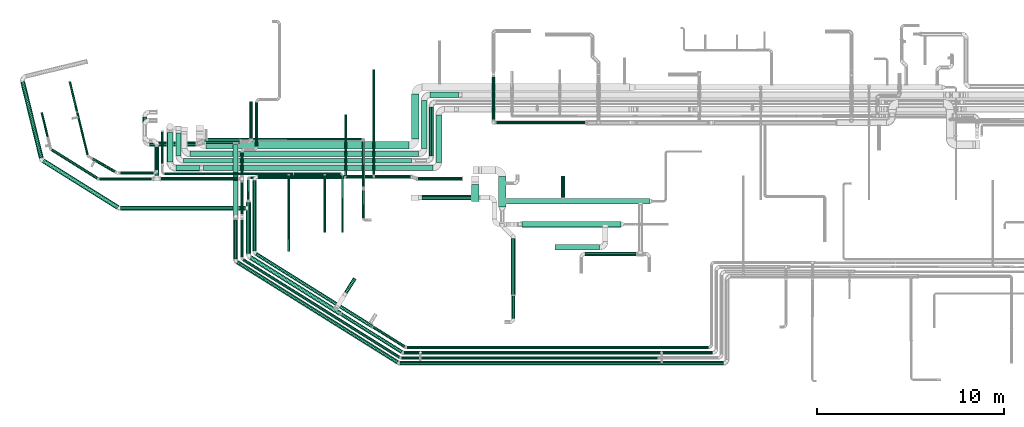
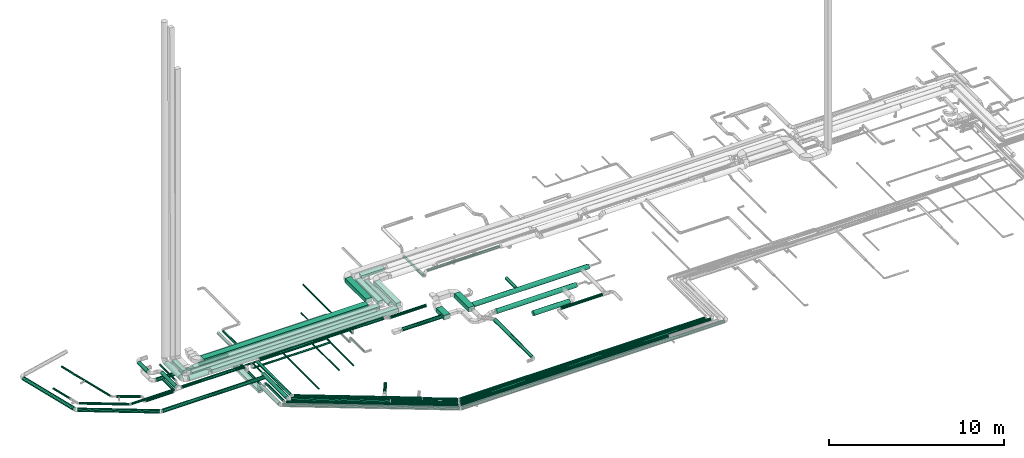
# One storey, part 30 of 92: 75 flow segments.
"""IFC2X3 building model written with IfcOpenShell, lengths in millimetres."""

import ifcopenshell
import ifcopenshell.guid

model = None  # the IFC model being written
_history = None  # IfcOwnerHistory: only IFC2X3 demands one
_inside = {}  # id of a spatial element -> (the spatial element, [elements in it])
_under = {}  # id of a project, library or spatial element -> (it, [spatial elements below it])
_declared = {}  # id of a project -> (the project, [libraries it declares])
_typed = {}  # id of a type object -> (the type object, [elements of that type])
_made_of = {}  # id of a material, layer set ... -> (it, [elements and type objects made of it])


def new_model(schema):
    """Start an empty IFC model of exactly this schema.

    Asked for "IFC4X3", IfcOpenShell would pick the latest addendum, in which some entities
    have other attributes; the version numbers below select the first issue.
    IFC2X3 requires an IfcOwnerHistory on every rooted entity: one is made here for all.
    """
    global model, _history
    if schema == "IFC4X3":
        model = ifcopenshell.file(schema_version=(4, 3, 0, 0))
    else:
        model = ifcopenshell.file(schema=schema)
    _inside.clear()
    _under.clear()
    _declared.clear()
    _typed.clear()
    _made_of.clear()
    _history = None
    if model.schema == "IFC2X3":
        org = make("IfcOrganization", Name="unknown")
        user = make(
            "IfcPersonAndOrganization",
            ThePerson=make("IfcPerson", FamilyName="unknown"),
            TheOrganization=org,
        )
        app = make(
            "IfcApplication",
            ApplicationDeveloper=org,
            Version="unknown",
            ApplicationFullName="unknown",
            ApplicationIdentifier="unknown",
        )
        _history = make(
            "IfcOwnerHistory",
            OwningUser=user,
            OwningApplication=app,
            ChangeAction="ADDED",
            CreationDate=0,
        )
    return model


def make(cls, **values):
    """One entity of the class cls with the attributes given. An attribute that is None is left unset."""
    return model.create_entity(
        cls, **{name: value for name, value in values.items() if value is not None}
    )


def entity(cls, *values):
    """Any entity or typed value of the class cls, its attributes in the order of the schema. None: left unset."""
    e = model.create_entity(cls)
    for i, value in enumerate(values):
        if value is not None:
            e[i] = value
    return e


def rooted(cls, **values):
    """An entity with a GlobalId (a new one), such as an element, a storey or a relation."""
    return make(cls, GlobalId=ifcopenshell.guid.new(), OwnerHistory=_history, **values)


def si_unit(unit_type, name, prefix=None):
    """IfcSIUnit, for example si_unit("LENGTHUNIT", "METRE", prefix="MILLI")."""
    return make("IfcSIUnit", UnitType=unit_type, Prefix=prefix, Name=name)


def converted_unit(unit_type, name, factor, base, dimensions=None, offset=None):
    """IfcConversionBasedUnit, such as the inch: factor (a typed value) times the base unit."""
    return make(
        "IfcConversionBasedUnit"
        if offset is None
        else "IfcConversionBasedUnitWithOffset",
        ConversionOffset=offset,
        Dimensions=None
        if dimensions is None
        else entity("IfcDimensionalExponents", *dimensions),
        UnitType=unit_type,
        Name=name,
        ConversionFactor=make(
            "IfcMeasureWithUnit", ValueComponent=factor, UnitComponent=base
        ),
    )


def derived_unit(unit_type, elements):
    """IfcDerivedUnit: a product of units, each with its exponent."""
    return make(
        "IfcDerivedUnit",
        Elements=[
            make("IfcDerivedUnitElement", Unit=unit, Exponent=power)
            for unit, power in elements
        ],
        UnitType=unit_type,
    )


def assignment(units):
    """IfcUnitAssignment: the units of a project."""
    return None if units is None else make("IfcUnitAssignment", Units=units)


def point(xyz):
    """IfcCartesianPoint."""
    return None if xyz is None else make("IfcCartesianPoint", Coordinates=xyz)


def direction(xyz):
    """IfcDirection."""
    return None if xyz is None else make("IfcDirection", DirectionRatios=xyz)


def frame(location, z_axis=None, x_axis=None):
    """IfcAxis2Placement3D, a coordinate frame: its origin and axes. An axis left out is left unset."""
    return make(
        "IfcAxis2Placement3D",
        Location=point(location),
        Axis=direction(z_axis),
        RefDirection=direction(x_axis),
    )


def frame_2d(location, x_axis=None):
    """IfcAxis2Placement2D, a coordinate frame in the plane: its origin and x axis."""
    return make(
        "IfcAxis2Placement2D", Location=point(location), RefDirection=direction(x_axis)
    )


def origin():
    """The frame at (0, 0, 0) with its axes left unset."""
    return frame((0.0, 0.0, 0.0))


def origin_2d_with_axis():
    """The frame at (0, 0) in the plane with the x axis (1, 0) written out."""
    return frame_2d((0.0, 0.0), x_axis=(1.0, 0.0))


def place(relative_to, where):
    """IfcLocalPlacement: puts the frame where relative to a parent placement (None: the world)."""
    return make(
        "IfcLocalPlacement", PlacementRelTo=relative_to, RelativePlacement=where
    )


def context(
    kind, dimensions, precision=None, world=None, true_north=None, identifier=None
):
    """IfcGeometricRepresentationContext, for example the 3D "Model" context."""
    return make(
        "IfcGeometricRepresentationContext",
        ContextIdentifier=identifier,
        ContextType=kind,
        CoordinateSpaceDimension=dimensions,
        Precision=precision,
        WorldCoordinateSystem=world,
        TrueNorth=true_north,
    )


def subcontext(parent, identifier, kind, view, scale=None):
    """IfcGeometricRepresentationSubContext, for example "Body" below "Model"."""
    return make(
        "IfcGeometricRepresentationSubContext",
        ContextIdentifier=identifier,
        ContextType=kind,
        ParentContext=parent,
        TargetScale=scale,
        TargetView=view,
    )


def project(units=None, contexts=None):
    """IfcProject with its units and contexts."""
    return rooted(
        "IfcProject",
        Name="project",
        RepresentationContexts=contexts,
        UnitsInContext=assignment(units),
    )


def spatial(cls, under=None, at=None, **own):
    """A site, building, storey or space (cls), placed at a placement, below another one or the project."""
    s = rooted(cls, ObjectPlacement=at, **own)
    if under is not None:
        _under.setdefault(under.id(), (under, []))[1].append(s)
    return s


def profile(cls, at=None, kind="AREA", **sizes):
    """A parametric profile (cls). Its sizes go by their IFC names, for example OverallWidth=200.0."""
    return make(cls, ProfileType=kind, Position=at, **sizes)


def rectangle(**sizes):
    """IfcRectangleProfileDef."""
    return profile("IfcRectangleProfileDef", **sizes)


def circle(**sizes):
    """IfcCircleProfileDef."""
    return profile("IfcCircleProfileDef", **sizes)


def extrude(swept, where, along, depth):
    """IfcExtrudedAreaSolid: the profile swept, set in the frame where, extruded along a direction by depth."""
    return make(
        "IfcExtrudedAreaSolid",
        SweptArea=swept,
        Position=where,
        ExtrudedDirection=direction(along),
        Depth=depth,
    )


def shape(context_of_items, identifier, shape_type, items):
    """IfcShapeRepresentation: the items that make up one representation, for example the "Body"."""
    return make(
        "IfcShapeRepresentation",
        ContextOfItems=context_of_items,
        RepresentationIdentifier=identifier,
        RepresentationType=shape_type,
        Items=items,
    )


def made_of(thing, what):
    """Note that an element or type object is made of a material, layer set ...; save() writes the relation."""
    if what is not None:
        _made_of.setdefault(what.id(), (what, []))[1].append(thing)
    return thing


def type_object(cls, material=None, **own):
    """A type object (cls), such as IfcWallType, which elements share."""
    return made_of(rooted(cls, **own), material)


def element(
    cls,
    number,
    at=None,
    inside=None,
    cuts=None,
    type_object=None,
    material=None,
    context=None,
    identifier="Body",
    shape_type=None,
    held_by="IfcProductDefinitionShape",
    body=None,
    shapes=None,
    **own,
):
    """One element of the class cls, such as IfcWall. Its Tag is "e" and its number.

    at: its placement. inside: the storey or other place that contains it. cuts: it is an
    opening in that element (IfcRelVoidsElement). A single representation is given by context,
    identifier, shape_type and body (its items); several are given by shapes. held_by: the class
    of the entity that holds the representations. save() writes the other relations.
    """
    e = rooted(cls, Tag="e%d" % number, ObjectPlacement=at, **own)
    if body is not None:
        shapes = [shape(context, identifier, shape_type, body)]
    if shapes is not None:
        e.Representation = make(held_by, Representations=shapes)
    if inside is not None:
        _inside.setdefault(inside.id(), (inside, []))[1].append(e)
    if cuts is not None:
        rooted(
            "IfcRelVoidsElement", RelatingBuildingElement=cuts, RelatedOpeningElement=e
        )
    if type_object is not None:
        _typed.setdefault(type_object.id(), (type_object, []))[1].append(e)
    return made_of(e, material)


def aggregate(whole, parts):
    """IfcRelAggregates: a whole, such as a stair, and the parts it consists of."""
    return rooted("IfcRelAggregates", RelatingObject=whole, RelatedObjects=parts)


def save(model, path):
    """Write the relations noted so far, then the file.

    IfcRelAggregates (storeys below a building ...), IfcRelContainedInSpatialStructure (elements
    in a storey), IfcRelDefinesByType, IfcRelAssociatesMaterial and IfcRelDeclares: one each for
    every whole, place, type object, material and project.
    """
    for whole, parts in _under.values():
        aggregate(whole, parts)
    for where, things in _inside.values():
        rooted(
            "IfcRelContainedInSpatialStructure",
            RelatedElements=things,
            RelatingStructure=where,
        )
    for kind, things in _typed.values():
        rooted("IfcRelDefinesByType", RelatedObjects=things, RelatingType=kind)
    for what, things in _made_of.values():
        rooted("IfcRelAssociatesMaterial", RelatedObjects=things, RelatingMaterial=what)
    for by, libraries in _declared.values():
        rooted("IfcRelDeclares", RelatingContext=by, RelatedDefinitions=libraries)
    model.write(path)


model = new_model("IFC2X3")

# Units and contexts
model_context = context("Model", 3, precision=0.01, world=origin(), true_north=direction((6.12303176911189e-17, 1.0)))
body_context = subcontext(model_context, "Body", "Model", "MODEL_VIEW")
ifc_project = project(units=[si_unit("LENGTHUNIT", "METRE", prefix="MILLI"), si_unit("AREAUNIT", "SQUARE_METRE"), si_unit("VOLUMEUNIT", "CUBIC_METRE"), converted_unit("PLANEANGLEUNIT", "DEGREE", entity("IfcRatioMeasure", 0.0174532925199433), si_unit("PLANEANGLEUNIT", "RADIAN"), dimensions=[0, 0, 0, 0, 0, 0, 0]), si_unit("MASSUNIT", "GRAM", prefix="KILO"), derived_unit("MASSDENSITYUNIT", [(si_unit("MASSUNIT", "GRAM", prefix="KILO"), 1), (si_unit("LENGTHUNIT", "METRE"), -3)]), derived_unit("MOMENTOFINERTIAUNIT", [(si_unit("LENGTHUNIT", "METRE"), 4)]), si_unit("TIMEUNIT", "SECOND"), si_unit("FREQUENCYUNIT", "HERTZ"), si_unit("THERMODYNAMICTEMPERATUREUNIT", "DEGREE_CELSIUS"), derived_unit("THERMALTRANSMITTANCEUNIT", [(si_unit("MASSUNIT", "GRAM", prefix="KILO"), 1), (si_unit("THERMODYNAMICTEMPERATUREUNIT", "KELVIN"), -1), (si_unit("TIMEUNIT", "SECOND"), -3)]), derived_unit("VOLUMETRICFLOWRATEUNIT", [(si_unit("LENGTHUNIT", "METRE"), 3), (si_unit("TIMEUNIT", "SECOND"), -1)]), derived_unit("MASSFLOWRATEUNIT", [(si_unit("MASSUNIT", "GRAM", prefix="KILO"), 1), (si_unit("TIMEUNIT", "SECOND"), -1)]), derived_unit("ROTATIONALFREQUENCYUNIT", [(si_unit("TIMEUNIT", "SECOND"), -1)]), si_unit("ELECTRICCURRENTUNIT", "AMPERE"), si_unit("ELECTRICVOLTAGEUNIT", "VOLT"), si_unit("POWERUNIT", "WATT"), si_unit("FORCEUNIT", "NEWTON", prefix="KILO"), si_unit("ILLUMINANCEUNIT", "LUX"), si_unit("LUMINOUSFLUXUNIT", "LUMEN"), si_unit("LUMINOUSINTENSITYUNIT", "CANDELA"), derived_unit("USERDEFINED", [(si_unit("MASSUNIT", "GRAM", prefix="KILO"), -1), (si_unit("LENGTHUNIT", "METRE"), -2), (si_unit("TIMEUNIT", "SECOND"), 3), (si_unit("LUMINOUSFLUXUNIT", "LUMEN"), 1)]), derived_unit("LINEARVELOCITYUNIT", [(si_unit("LENGTHUNIT", "METRE"), 1), (si_unit("TIMEUNIT", "SECOND"), -1)]), si_unit("PRESSUREUNIT", "PASCAL"), derived_unit("USERDEFINED", [(si_unit("LENGTHUNIT", "METRE"), -2), (si_unit("MASSUNIT", "GRAM", prefix="KILO"), 1), (si_unit("TIMEUNIT", "SECOND"), -2)]), derived_unit("LINEARFORCEUNIT", [(si_unit("MASSUNIT", "GRAM", prefix="KILO"), 1), (si_unit("LENGTHUNIT", "METRE"), 1), (si_unit("TIMEUNIT", "SECOND"), -2), (si_unit("LENGTHUNIT", "METRE"), -1)]), derived_unit("PLANARFORCEUNIT", [(si_unit("MASSUNIT", "GRAM", prefix="KILO"), 1), (si_unit("LENGTHUNIT", "METRE"), 1), (si_unit("TIMEUNIT", "SECOND"), -2), (si_unit("LENGTHUNIT", "METRE"), -2)])], contexts=[model_context])

# Site, building, storey
site_placement = place(None, origin())
site = spatial("IfcSite", under=ifc_project, at=site_placement, CompositionType="ELEMENT")
building_placement = place(site_placement, origin())
building = spatial("IfcBuilding", under=site, at=building_placement, CompositionType="ELEMENT")
storey_placement = place(building_placement, frame((0.0, 0.0, 4200.0)))
storey = spatial("IfcBuildingStorey", under=building, at=storey_placement, CompositionType="ELEMENT", Elevation=4200.0)

# Flow segments
duct_segment_type_1 = type_object("IfcDuctSegmentType", PredefinedType="NOTDEFINED")
flow_segment_1_placement = place(storey_placement, frame((11979.27, 9071.64, 2865.0)))
element("IfcFlowSegment", 1, at=flow_segment_1_placement, inside=storey, type_object=duct_segment_type_1, context=body_context, shape_type="SweptSolid", body=[
    extrude(rectangle(XDim=4008.35652193022, YDim=249.999999999999, at=origin_2d_with_axis()), frame((125.0, 2004.18, 0.0), z_axis=(0.0, 0.0, 1.0), x_axis=(0.0, -1.0, 0.0)), (0.0, 0.0, 1.0), 150.000000000001),
])
flow_segment_2_placement = place(storey_placement, frame((10383.35, 11669.68, 3200.0)))
element("IfcFlowSegment", 2, at=flow_segment_2_placement, inside=storey, type_object=duct_segment_type_1, context=body_context, shape_type="SweptSolid", body=[
    extrude(rectangle(XDim=12281.7247260222, YDim=299.999999999999, at=origin_2d_with_axis()), frame((6140.86, 150.0, 0.0), z_axis=(0.0, 0.0, 1.0), x_axis=(-1.0, 0.0, 0.0)), (0.0, 0.0, 1.0), 249.999999999999),
])
flow_segment_3_placement = place(storey_placement, frame((22815.08, 12119.68, 3200.0)))
element("IfcFlowSegment", 3, at=flow_segment_3_placement, inside=storey, type_object=duct_segment_type_1, context=body_context, shape_type="SweptSolid", body=[
    extrude(rectangle(XDim=2537.31427635606, YDim=300.000000000001, at=origin_2d_with_axis()), frame((150.0, 1268.66, 0.0), z_axis=(0.0, 0.0, 1.0), x_axis=(0.0, 1.0, 0.0)), (0.0, 0.0, 1.0), 249.999999999999),
])
flow_segment_4_placement = place(storey_placement, frame((22042.16, 12869.66, 3200.0)))
element("IfcFlowSegment", 4, at=flow_segment_4_placement, inside=storey, type_object=duct_segment_type_1, context=body_context, shape_type="SweptSolid", body=[
    extrude(rectangle(XDim=2552.34371029157, YDim=300.000000000001, at=origin_2d_with_axis()), frame((150.0, 1276.17, 0.0), z_axis=(0.0, 0.0, 1.0), x_axis=(0.0, 1.0, 0.0)), (0.0, 0.0, 1.0), 200.0),
])
flow_segment_5_placement = place(storey_placement, frame((22492.16, 15572.0, 3200.0)))
element("IfcFlowSegment", 5, at=flow_segment_5_placement, inside=storey, type_object=duct_segment_type_1, context=body_context, shape_type="SweptSolid", body=[
    extrude(rectangle(XDim=1522.98135691757, YDim=299.999999999999, at=origin_2d_with_axis()), frame((761.49, 150.0, 0.0)), (0.0, 0.0, 1.0), 200.0),
])
flow_segment_6_placement = place(storey_placement, frame((21525.0, 13369.63, 3150.0)))
element("IfcFlowSegment", 6, at=flow_segment_6_placement, inside=storey, type_object=duct_segment_type_1, context=body_context, shape_type="SweptSolid", body=[
    extrude(rectangle(XDim=2404.88181878153, YDim=400.0, at=origin_2d_with_axis()), frame((200.0, 1202.44, 0.0), z_axis=(0.0, 0.0, 1.0), x_axis=(0.0, -1.0, 0.0)), (0.0, 0.0, 1.0), 300.000000000001),
])
flow_segment_7_placement = place(storey_placement, frame((10530.0, 12819.63, 3150.0)))
element("IfcFlowSegment", 7, at=flow_segment_7_placement, inside=storey, type_object=duct_segment_type_1, context=body_context, shape_type="SweptSolid", body=[
    extrude(rectangle(XDim=10844.9999999999, YDim=400.0, at=origin_2d_with_axis()), frame((5422.5, 200.0, 0.0)), (0.0, 0.0, 1.0), 300.000000000001),
])
flow_segment_8_placement = place(storey_placement, frame((26160.0, 9716.65, 3150.0)))
element("IfcFlowSegment", 8, at=flow_segment_8_placement, inside=storey, type_object=duct_segment_type_1, context=body_context, shape_type="SweptSolid", body=[
    extrude(rectangle(XDim=1632.29754765695, YDim=400.0, at=origin_2d_with_axis()), frame((200.0, 816.15, 0.0), z_axis=(0.0, 0.0, 1.0), x_axis=(0.0, -1.0, 0.0)), (0.0, 0.0, 1.0), 300.000000000001),
])
flow_segment_9_placement = place(storey_placement, frame((9664.47, 12419.66, 3200.0)))
element("IfcFlowSegment", 9, at=flow_segment_9_placement, inside=storey, type_object=duct_segment_type_1, context=body_context, shape_type="SweptSolid", body=[
    extrude(rectangle(XDim=12227.691663082, YDim=300.000000000001, at=origin_2d_with_axis()), frame((6113.85, 150.0, 0.0)), (0.0, 0.0, 1.0), 200.0),
])
flow_segment_10_placement = place(storey_placement, frame((9324.12, 12069.64, 3200.0)))
element("IfcFlowSegment", 10, at=flow_segment_10_placement, inside=storey, type_object=duct_segment_type_1, context=body_context, shape_type="SweptSolid", body=[
    extrude(rectangle(XDim=12199.9289354935, YDim=249.999999999999, at=origin_2d_with_axis()), frame((6099.96, 125.0, 0.0)), (0.0, 0.0, 1.0), 200.0),
])
flow_segment_11_placement = place(storey_placement, frame((8924.12, 12469.64, 3200.0)))
element("IfcFlowSegment", 11, at=flow_segment_11_placement, inside=storey, type_object=duct_segment_type_1, context=body_context, shape_type="SweptSolid", body=[
    extrude(rectangle(XDim=1214.24739279422, YDim=250.000000000001, at=origin_2d_with_axis()), frame((125.0, 607.12, 0.0), z_axis=(0.0, 0.0, 1.0), x_axis=(0.0, 1.0, 0.0)), (0.0, 0.0, 1.0), 200.0),
])
flow_segment_12_placement = place(storey_placement, frame((24733.23, 10032.07, 2900.0)))
element("IfcFlowSegment", 12, at=flow_segment_12_placement, inside=storey, type_object=duct_segment_type_1, context=body_context, shape_type="SweptSolid", body=[
    extrude(rectangle(XDim=892.922436430332, YDim=400.0, at=origin_2d_with_axis()), frame((200.0, 446.46, 0.0), z_axis=(0.0, 0.0, 1.0), x_axis=(0.0, -1.0, 0.0)), (0.0, 0.0, 1.0), 300.000000000001),
])
duct_segment_type_2 = type_object("IfcDuctSegmentType", PredefinedType="NOTDEFINED")
flow_segment_13_placement = place(storey_placement, frame((22444.38, 12444.64, 3173.4)))
element("IfcFlowSegment", 13, at=flow_segment_13_placement, inside=storey, type_object=duct_segment_type_2, context=body_context, shape_type="SweptSolid", body=[
    extrude(circle(Radius=125.0, at=origin_2d_with_axis()), frame((126.6, 0.0, 126.6), z_axis=(0.0, 1.0, 0.0), x_axis=(1.0, 0.0, 0.0)), (0.0, 0.0, 1.0), 2644.85632414976),
])
flow_segment_14_placement = place(storey_placement, frame((2224.81, 11192.07, 3218.4)))
element("IfcFlowSegment", 14, at=flow_segment_14_placement, inside=storey, type_object=duct_segment_type_2, context=body_context, shape_type="SweptSolid", body=[
    extrude(circle(Radius=80.0, at=origin_2d_with_axis()), frame((2491.31, 69.44, 81.6), z_axis=(-0.848052743777569, 0.529911826412034, 0.0), x_axis=(0.529911826412034, 0.848052743777569, 0.0)), (0.0, 0.0, 1.0), 2885.81371680738),
])
flow_segment_15_placement = place(storey_placement, frame((8115.09, 11135.6, 3198.4)))
element("IfcFlowSegment", 15, at=flow_segment_15_placement, inside=storey, type_object=duct_segment_type_2, context=body_context, shape_type="SweptSolid", body=[
    extrude(circle(Radius=100.0, at=origin_2d_with_axis()), frame((0.0, 101.6, 101.6), z_axis=(1.0, 0.0, 0.0), x_axis=(0.0, 1.0, 0.0)), (0.0, 0.0, 1.0), 4127.92522938783),
])
flow_segment_16_placement = place(storey_placement, frame((12361.42, 9366.78, 2858.4)))
element("IfcFlowSegment", 16, at=flow_segment_16_placement, inside=storey, type_object=duct_segment_type_2, context=body_context, shape_type="SweptSolid", body=[
    extrude(circle(Radius=80.0, at=origin_2d_with_axis()), frame((81.6, 0.0, 81.6), z_axis=(0.0, 1.0, 0.0), x_axis=(1.0, 0.0, 0.0)), (0.0, 0.0, 1.0), 1680.40830885769),
])
flow_segment_17_placement = place(storey_placement, frame((12361.42, 11427.19, 2858.4)))
element("IfcFlowSegment", 17, at=flow_segment_17_placement, inside=storey, type_object=duct_segment_type_2, context=body_context, shape_type="SweptSolid", body=[
    extrude(circle(Radius=80.0, at=origin_2d_with_axis()), frame((81.6, 0.0, 81.6), z_axis=(0.0, 1.0, 0.0), x_axis=(-1.0, 0.0, 0.0)), (0.0, 0.0, 1.0), 1226.37318023074),
])
flow_segment_18_placement = place(storey_placement, frame((13153.19, 12973.57, 2858.4)))
element("IfcFlowSegment", 18, at=flow_segment_18_placement, inside=storey, type_object=duct_segment_type_2, context=body_context, shape_type="SweptSolid", body=[
    extrude(circle(Radius=80.0, at=origin_2d_with_axis()), frame((81.6, 0.0, 81.6), z_axis=(0.0, 1.0, 0.0), x_axis=(1.0, 0.0, 0.0)), (0.0, 0.0, 1.0), 2346.14737091158),
])
flow_segment_19_placement = place(storey_placement, frame((20962.91, 1578.33, 3288.4)))
element("IfcFlowSegment", 19, at=flow_segment_19_placement, inside=storey, type_object=duct_segment_type_2, context=body_context, shape_type="SweptSolid", body=[
    extrude(circle(Radius=80.0, at=origin_2d_with_axis()), frame((0.0, 81.6, 81.6), z_axis=(1.0, 0.0, 0.0), x_axis=(0.0, -1.0, 0.0)), (0.0, 0.0, 1.0), 13720.4167618418),
])
flow_segment_20_placement = place(storey_placement, frame((4412.95, 11548.76, 3218.4)))
element("IfcFlowSegment", 20, at=flow_segment_20_placement, inside=storey, type_object=duct_segment_type_2, context=body_context, shape_type="SweptSolid", body=[
    extrude(circle(Radius=80.0, at=origin_2d_with_axis()), frame((1233.26, 70.88, 81.6), z_axis=(-0.866025403784431, 0.500000000000013, 0.0), x_axis=(0.500000000000013, 0.866025403784431, 0.0)), (0.0, 0.0, 1.0), 1376.01358912734),
])
flow_segment_21_placement = place(storey_placement, frame((3184.92, 14805.33, 3248.4)))
element("IfcFlowSegment", 21, at=flow_segment_21_placement, inside=storey, type_object=duct_segment_type_2, context=body_context, shape_type="SweptSolid", body=[
    extrude(circle(Radius=50.0, at=origin_2d_with_axis()), frame((442.66, 13.44, 51.6), z_axis=(-0.236826092990338, 0.971552058141473, 0.0), x_axis=(0.971552058141473, 0.236826092990338, 0.0)), (0.0, 0.0, 1.0), 1657.29271421731),
])
flow_segment_22_placement = place(storey_placement, frame((3571.19, 12486.99, 3235.9)))
element("IfcFlowSegment", 22, at=flow_segment_22_placement, inside=storey, type_object=duct_segment_type_2, context=body_context, shape_type="SweptSolid", body=[
    extrude(circle(Radius=62.5, at=origin_2d_with_axis()), frame((620.65, 16.39, 64.1), z_axis=(-0.236766062236588, 0.971566689308037, 0.0), x_axis=(0.971566689308037, 0.236766062236588, 0.0)), (0.0, 0.0, 1.0), 2358.13764512989),
])
flow_segment_23_placement = place(storey_placement, frame((12143.71, 1323.96, 3248.4)))
element("IfcFlowSegment", 23, at=flow_segment_23_placement, inside=storey, type_object=duct_segment_type_2, context=body_context, shape_type="SweptSolid", body=[
    extrude(circle(Radius=100.0, at=origin_2d_with_axis()), frame((54.59, 5453.88, 101.6), z_axis=(0.848052743777567, -0.529911826412037, 0.0), x_axis=(-0.529911826412037, -0.848052743777567, 0.0)), (0.0, 0.0, 1.0), 10129.0097516461),
])
flow_segment_24_placement = place(storey_placement, frame((12853.53, 13380.0, 2818.4)))
element("IfcFlowSegment", 24, at=flow_segment_24_placement, inside=storey, type_object=duct_segment_type_2, context=body_context, shape_type="SweptSolid", body=[
    extrude(circle(Radius=80.0, at=origin_2d_with_axis()), frame((81.6, 0.0, 81.6), z_axis=(0.0, 1.0, 0.0), x_axis=(1.0, 0.0, 0.0)), (0.0, 0.0, 1.0), 1990.99106011782),
])
flow_segment_25_placement = place(storey_placement, frame((20894.21, 1278.38, 3248.4)))
element("IfcFlowSegment", 25, at=flow_segment_25_placement, inside=storey, type_object=duct_segment_type_2, context=body_context, shape_type="SweptSolid", body=[
    extrude(circle(Radius=100.0, at=origin_2d_with_axis()), frame((0.0, 101.6, 101.6), z_axis=(1.0, 0.0, 0.0), x_axis=(0.0, -1.0, 0.0)), (0.0, 0.0, 1.0), 17295.5336074922),
])
flow_segment_26_placement = place(storey_placement, frame((21859.59, 11132.1, 3258.4)))
element("IfcFlowSegment", 26, at=flow_segment_26_placement, inside=storey, type_object=duct_segment_type_2, context=body_context, shape_type="SweptSolid", body=[
    extrude(circle(Radius=100.0, at=origin_2d_with_axis()), frame((0.0, 101.6, 101.6), z_axis=(1.0, 0.0, 0.0), x_axis=(0.0, 1.0, 0.0)), (0.0, 0.0, 1.0), 2362.70931140369),
])
flow_segment_27_placement = place(storey_placement, frame((13313.91, 11248.38, 3258.4)))
element("IfcFlowSegment", 27, at=flow_segment_27_placement, inside=storey, type_object=duct_segment_type_2, context=body_context, shape_type="SweptSolid", body=[
    extrude(circle(Radius=100.0, at=origin_2d_with_axis()), frame((0.0, 101.6, 101.6), z_axis=(1.0, 0.0, 0.0), x_axis=(0.0, -1.0, 0.0)), (0.0, 0.0, 1.0), 8170.11312268674),
])
flow_segment_28_placement = place(storey_placement, frame((13012.31, 7386.05, 3258.4)))
element("IfcFlowSegment", 28, at=flow_segment_28_placement, inside=storey, type_object=duct_segment_type_2, context=body_context, shape_type="SweptSolid", body=[
    extrude(circle(Radius=100.0, at=origin_2d_with_axis()), frame((101.6, 0.0, 101.6), z_axis=(0.0, 1.0, 0.0), x_axis=(1.0, 0.0, 0.0)), (0.0, 0.0, 1.0), 3763.92946490348),
])
flow_segment_29_placement = place(storey_placement, frame((13153.34, 3251.73, 3258.4)))
element("IfcFlowSegment", 29, at=flow_segment_29_placement, inside=storey, type_object=duct_segment_type_2, context=body_context, shape_type="SweptSolid", body=[
    extrude(circle(Radius=100.0, at=origin_2d_with_axis()), frame((54.59, 3964.71, 101.6), z_axis=(0.848050921451727, -0.529914742788759, 0.0), x_axis=(-0.529914742788759, -0.848050921451727, 0.0)), (0.0, 0.0, 1.0), 7318.7442494566),
])
flow_segment_30_placement = place(storey_placement, frame((21249.87, 2138.4, 3278.4)))
element("IfcFlowSegment", 30, at=flow_segment_30_placement, inside=storey, type_object=duct_segment_type_2, context=body_context, shape_type="SweptSolid", body=[
    extrude(circle(Radius=80.0, at=origin_2d_with_axis()), frame((0.0, 81.6, 81.6), z_axis=(1.0, 0.0, 0.0), x_axis=(0.0, -1.0, 0.0)), (0.0, 0.0, 1.0), 16145.0037495196),
])
flow_segment_31_placement = place(storey_placement, frame((22078.23, 10106.06, 2923.4)))
element("IfcFlowSegment", 31, at=flow_segment_31_placement, inside=storey, type_object=duct_segment_type_2, context=body_context, shape_type="SweptSolid", body=[
    extrude(circle(Radius=125.0, at=origin_2d_with_axis()), frame((0.0, 126.6, 126.6), z_axis=(1.0, 0.0, 0.0), x_axis=(0.0, 1.0, 0.0)), (0.0, 0.0, 1.0), 2634.99999999999),
])
flow_segment_32_placement = place(storey_placement, frame((8442.31, 12134.68, 3133.4)))
element("IfcFlowSegment", 32, at=flow_segment_32_placement, inside=storey, type_object=duct_segment_type_2, context=body_context, shape_type="SweptSolid", body=[
    extrude(circle(Radius=157.5, at=origin_2d_with_axis()), frame((159.1, 0.0, 159.1), z_axis=(0.0, 1.0, 0.0), x_axis=(1.0, 0.0, 0.0)), (0.0, 0.0, 1.0), 1567.03368000002),
])
flow_segment_33_placement = place(storey_placement, frame((8916.41, 11660.59, 3133.4)))
element("IfcFlowSegment", 33, at=flow_segment_33_placement, inside=storey, type_object=duct_segment_type_2, context=body_context, shape_type="SweptSolid", body=[
    extrude(circle(Radius=157.5, at=origin_2d_with_axis()), frame((0.0, 159.1, 159.1), z_axis=(1.0, 0.0, 0.0), x_axis=(0.0, -1.0, 0.0)), (0.0, 0.0, 1.0), 1266.94760898472),
])
flow_segment_34_placement = place(storey_placement, frame((8125.6, 12059.82, 3235.9)))
element("IfcFlowSegment", 34, at=flow_segment_34_placement, inside=storey, type_object=duct_segment_type_2, context=body_context, shape_type="SweptSolid", body=[
    extrude(circle(Radius=62.5, at=origin_2d_with_axis()), frame((64.1, 0.0, 64.1), z_axis=(0.0, 1.0, 0.0), x_axis=(1.0, 0.0, 0.0)), (0.0, 0.0, 1.0), 1699.08266611749),
])
flow_segment_35_placement = place(storey_placement, frame((8314.69, 11435.58, 3085.9)))
element("IfcFlowSegment", 35, at=flow_segment_35_placement, inside=storey, type_object=duct_segment_type_2, context=body_context, shape_type="SweptSolid", body=[
    extrude(circle(Radius=62.5, at=origin_2d_with_axis()), frame((0.0, 64.1, 64.1), z_axis=(1.0, 0.0, 0.0), x_axis=(0.0, 1.0, 0.0)), (0.0, 0.0, 1.0), 6879.99999999999),
])
flow_segment_36_placement = place(storey_placement, frame((15219.69, 11448.08, 3098.4)))
element("IfcFlowSegment", 36, at=flow_segment_36_placement, inside=storey, type_object=duct_segment_type_2, context=body_context, shape_type="SweptSolid", body=[
    extrude(circle(Radius=50.0, at=origin_2d_with_axis()), frame((0.0, 51.6, 51.6), z_axis=(1.0, 0.0, 0.0), x_axis=(0.0, 1.0, 0.0)), (0.0, 0.0, 1.0), 2500.53197),
])
flow_segment_37_placement = place(storey_placement, frame((16819.3, 8380.21, 3098.4)))
element("IfcFlowSegment", 37, at=flow_segment_37_placement, inside=storey, type_object=duct_segment_type_2, context=body_context, shape_type="SweptSolid", body=[
    extrude(circle(Radius=50.0, at=origin_2d_with_axis()), frame((51.6, 0.0, 51.6), z_axis=(0.0, 1.0, 0.0), x_axis=(-1.0, 0.0, 0.0)), (0.0, 0.0, 1.0), 3049.46556175872),
])
flow_segment_38_placement = place(storey_placement, frame((17768.63, 8380.21, 3098.4)))
element("IfcFlowSegment", 38, at=flow_segment_38_placement, inside=storey, type_object=duct_segment_type_2, context=body_context, shape_type="SweptSolid", body=[
    extrude(circle(Radius=50.0, at=origin_2d_with_axis()), frame((51.6, 0.0, 51.6), z_axis=(0.0, 1.0, 0.0), x_axis=(-1.0, 0.0, 0.0)), (0.0, 0.0, 1.0), 3019.46556175873),
])
flow_segment_39_placement = place(storey_placement, frame((14898.83, 7349.94, 3098.4)))
element("IfcFlowSegment", 39, at=flow_segment_39_placement, inside=storey, type_object=duct_segment_type_2, context=body_context, shape_type="SweptSolid", body=[
    extrude(circle(Radius=50.0, at=origin_2d_with_axis()), frame((51.6, 0.0, 51.6), z_axis=(0.0, 1.0, 0.0), x_axis=(-1.0, 0.0, 0.0)), (0.0, 0.0, 1.0), 4067.23493880683),
])
flow_segment_40_placement = place(storey_placement, frame((596.13, 12319.04, 3233.4)))
element("IfcFlowSegment", 40, at=flow_segment_40_placement, inside=storey, type_object=duct_segment_type_2, context=body_context, shape_type="SweptSolid", body=[
    extrude(circle(Radius=125.0, at=origin_2d_with_axis()), frame((1115.65, 31.2, 126.6), z_axis=(-0.236826092990331, 0.971552058141475, 0.0), x_axis=(0.971552058141475, 0.236826092990331, 0.0)), (0.0, 0.0, 1.0), 4191.30986231619),
])
flow_segment_41_placement = place(storey_placement, frame((1754.36, 9597.52, 3233.4)))
element("IfcFlowSegment", 41, at=flow_segment_41_placement, inside=storey, type_object=duct_segment_type_2, context=body_context, shape_type="SweptSolid", body=[
    extrude(circle(Radius=125.0, at=origin_2d_with_axis()), frame((67.83, 2599.91, 126.6), z_axis=(0.848052743777565, -0.52991182641204, 0.0), x_axis=(-0.52991182641204, -0.848052743777565, 0.0)), (0.0, 0.0, 1.0), 4703.25156193283),
])
flow_segment_42_placement = place(storey_placement, frame((5943.27, 9540.54, 3233.4)))
element("IfcFlowSegment", 42, at=flow_segment_42_placement, inside=storey, type_object=duct_segment_type_2, context=body_context, shape_type="SweptSolid", body=[
    extrude(circle(Radius=125.0, at=origin_2d_with_axis()), frame((0.0, 126.6, 126.6), z_axis=(1.0, 0.0, 0.0), x_axis=(0.0, -1.0, 0.0)), (0.0, 0.0, 1.0), 6702.2223688425),
])
flow_segment_43_placement = place(storey_placement, frame((12890.5, 11238.35, 2898.4)))
element("IfcFlowSegment", 43, at=flow_segment_43_placement, inside=storey, type_object=duct_segment_type_2, context=body_context, shape_type="SweptSolid", body=[
    extrude(circle(Radius=50.0, at=origin_2d_with_axis()), frame((0.0, 51.6, 51.6), z_axis=(1.0, 0.0, 0.0), x_axis=(0.0, 1.0, 0.0)), (0.0, 0.0, 1.0), 4999.56629174314),
])
flow_segment_44_placement = place(storey_placement, frame((17938.47, 11389.94, 2898.4)))
element("IfcFlowSegment", 44, at=flow_segment_44_placement, inside=storey, type_object=duct_segment_type_2, context=body_context, shape_type="SweptSolid", body=[
    extrude(circle(Radius=50.0, at=origin_2d_with_axis()), frame((51.6, 0.0, 51.6), z_axis=(0.0, 1.0, 0.0), x_axis=(1.0, 0.0, 0.0)), (0.0, 0.0, 1.0), 3277.19764315929),
])
flow_segment_45_placement = place(storey_placement, frame((12663.9, 7236.19, 3233.4)))
element("IfcFlowSegment", 45, at=flow_segment_45_placement, inside=storey, type_object=duct_segment_type_2, context=body_context, shape_type="SweptSolid", body=[
    extrude(circle(Radius=125.0, at=origin_2d_with_axis()), frame((126.6, 0.0, 126.6), z_axis=(0.0, 1.0, 0.0), x_axis=(1.0, 0.0, 0.0)), (0.0, 0.0, 1.0), 2740.94520394888),
])
flow_segment_46_placement = place(storey_placement, frame((12840.18, 3920.53, 3233.4)))
element("IfcFlowSegment", 46, at=flow_segment_46_placement, inside=storey, type_object=duct_segment_type_2, context=body_context, shape_type="SweptSolid", body=[
    extrude(circle(Radius=125.0, at=origin_2d_with_axis()), frame((67.83, 3103.65, 126.6), z_axis=(0.848052780606251, -0.529911767472667, 0.0), x_axis=(-0.529911767472667, -0.848052780606251, 0.0)), (0.0, 0.0, 1.0), 5653.85760191674),
])
flow_segment_47_placement = place(storey_placement, frame((17690.6, 1883.95, 3258.4)))
element("IfcFlowSegment", 47, at=flow_segment_47_placement, inside=storey, type_object=duct_segment_type_2, context=body_context, shape_type="SweptSolid", body=[
    extrude(circle(Radius=100.0, at=origin_2d_with_axis()), frame((54.59, 2117.69, 101.6), z_axis=(0.848052780606254, -0.529911767472662, 0.0), x_axis=(0.529911767472662, 0.848052780606254, 0.0)), (0.0, 0.0, 1.0), 3833.25959425514),
])
flow_segment_48_placement = place(storey_placement, frame((21101.98, 1838.37, 3258.4)))
element("IfcFlowSegment", 48, at=flow_segment_48_placement, inside=storey, type_object=duct_segment_type_2, context=body_context, shape_type="SweptSolid", body=[
    extrude(circle(Radius=100.0, at=origin_2d_with_axis()), frame((0.0, 101.6, 101.6), z_axis=(1.0, 0.0, 0.0), x_axis=(0.0, -1.0, 0.0)), (0.0, 0.0, 1.0), 16517.1536315162),
])
flow_segment_49_placement = place(storey_placement, frame((26051.62, 14160.4, 3261.1)))
element("IfcFlowSegment", 49, at=flow_segment_49_placement, inside=storey, type_object=duct_segment_type_2, context=body_context, shape_type="SweptSolid", body=[
    extrude(circle(Radius=80.0, at=origin_2d_with_axis()), frame((0.0, 81.6, 81.6), z_axis=(1.0, 0.0, 0.0), x_axis=(0.0, -1.0, 0.0)), (0.0, 0.0, 1.0), 4759.98447387883),
])
flow_segment_50_placement = place(storey_placement, frame((18890.46, 9138.08, 3248.4)))
element("IfcFlowSegment", 50, at=flow_segment_50_placement, inside=storey, type_object=duct_segment_type_2, context=body_context, shape_type="SweptSolid", body=[
    extrude(circle(Radius=50.0, at=origin_2d_with_axis()), frame((51.6, 0.0, 51.6), z_axis=(0.0, 1.0, 0.0), x_axis=(1.0, 0.0, 0.0)), (0.0, 0.0, 1.0), 1487.36657000001),
])
flow_segment_51_placement = place(storey_placement, frame((18890.46, 10825.45, 2898.4)))
element("IfcFlowSegment", 51, at=flow_segment_51_placement, inside=storey, type_object=duct_segment_type_2, context=body_context, shape_type="SweptSolid", body=[
    extrude(circle(Radius=50.0, at=origin_2d_with_axis()), frame((51.6, 0.0, 51.6), z_axis=(0.0, 1.0, 0.0), x_axis=(1.0, 0.0, 0.0)), (0.0, 0.0, 1.0), 2428.82870077379),
])
flow_segment_52_placement = place(storey_placement, frame((10624.9, 13302.68, 3248.4)))
element("IfcFlowSegment", 52, at=flow_segment_52_placement, inside=storey, type_object=duct_segment_type_2, context=body_context, shape_type="SweptSolid", body=[
    extrude(circle(Radius=50.0, at=origin_2d_with_axis()), frame((0.0, 51.6, 51.6), z_axis=(1.0, 0.0, 0.0), x_axis=(0.0, 1.0, 0.0)), (0.0, 0.0, 1.0), 8217.15723586536),
])
flow_segment_53_placement = place(storey_placement, frame((26828.4, 5027.95, 3198.4)))
element("IfcFlowSegment", 53, at=flow_segment_53_placement, inside=storey, type_object=duct_segment_type_2, context=body_context, shape_type="SweptSolid", body=[
    extrude(circle(Radius=125.0, at=origin_2d_with_axis()), frame((126.6, 0.0, 126.6), z_axis=(0.0, 1.0, 0.0), x_axis=(-1.0, 0.0, 0.0)), (0.0, 0.0, 1.0), 3015.86298183568),
])
flow_segment_54_placement = place(storey_placement, frame((26853.4, 3775.29, 3223.4)))
element("IfcFlowSegment", 54, at=flow_segment_54_placement, inside=storey, type_object=duct_segment_type_2, context=body_context, shape_type="SweptSolid", body=[
    extrude(circle(Radius=100.0, at=origin_2d_with_axis()), frame((101.6, 0.0, 101.6), z_axis=(0.0, 1.0, 0.0), x_axis=(-1.0, 0.0, 0.0)), (0.0, 0.0, 1.0), 1202.65580957695),
])
flow_segment_55_placement = place(storey_placement, frame((26580.0, 9878.86, 3140.9)))
element("IfcFlowSegment", 55, at=flow_segment_55_placement, inside=storey, type_object=duct_segment_type_2, context=body_context, shape_type="SweptSolid", body=[
    extrude(circle(Radius=157.5, at=origin_2d_with_axis()), frame((0.0, 159.1, 159.1), z_axis=(1.0, 0.0, 0.0), x_axis=(0.0, 1.0, 0.0)), (0.0, 0.0, 1.0), 7659.99999999999),
])
flow_segment_56_placement = place(storey_placement, frame((29513.54, 10215.46, 3198.4)))
element("IfcFlowSegment", 56, at=flow_segment_56_placement, inside=storey, type_object=duct_segment_type_2, context=body_context, shape_type="SweptSolid", body=[
    extrude(circle(Radius=100.0, at=origin_2d_with_axis()), frame((101.6, 0.0, 101.6), z_axis=(0.0, 1.0, 0.0), x_axis=(1.0, 0.0, 0.0)), (0.0, 0.0, 1.0), 1159.99999999999),
])
flow_segment_57_placement = place(storey_placement, frame((30797.77, 7117.69, 3198.4)))
element("IfcFlowSegment", 57, at=flow_segment_57_placement, inside=storey, type_object=duct_segment_type_2, context=body_context, shape_type="SweptSolid", body=[
    extrude(circle(Radius=100.0, at=origin_2d_with_axis()), frame((0.0, 101.6, 101.6), z_axis=(1.0, 0.0, 0.0), x_axis=(0.0, 1.0, 0.0)), (0.0, 0.0, 1.0), 2734.89883282875),
])
flow_segment_58_placement = place(storey_placement, frame((29175.14, 7417.28, 3140.9)))
element("IfcFlowSegment", 58, at=flow_segment_58_placement, inside=storey, type_object=duct_segment_type_2, context=body_context, shape_type="SweptSolid", body=[
    extrude(circle(Radius=157.5, at=origin_2d_with_axis()), frame((0.0, 159.1, 159.1), z_axis=(1.0, 0.0, 0.0), x_axis=(0.0, 1.0, 0.0)), (0.0, 0.0, 1.0), 2387.06345001776),
])
flow_segment_59_placement = place(storey_placement, frame((10424.44, 13093.4, 2773.4)))
element("IfcFlowSegment", 59, at=flow_segment_59_placement, inside=storey, type_object=duct_segment_type_2, context=body_context, shape_type="SweptSolid", body=[
    extrude(circle(Radius=125.0, at=origin_2d_with_axis()), frame((0.0, 126.6, 126.6), z_axis=(1.0, 0.0, 0.0), x_axis=(0.0, 1.0, 0.0)), (0.0, 0.0, 1.0), 1899.83330141568),
])
flow_segment_60_placement = place(storey_placement, frame((7805.2, 11699.63, 2838.4)))
element("IfcFlowSegment", 60, at=flow_segment_60_placement, inside=storey, type_object=duct_segment_type_2, context=body_context, shape_type="SweptSolid", body=[
    extrude(circle(Radius=80.0, at=origin_2d_with_axis()), frame((81.6, 0.0, 81.6), z_axis=(0.0, 1.0, 0.0), x_axis=(1.0, 0.0, 0.0)), (0.0, 0.0, 1.0), 1252.0103732076),
])
flow_segment_61_placement = place(storey_placement, frame((5944.77, 11458.04, 2838.4)))
element("IfcFlowSegment", 61, at=flow_segment_61_placement, inside=storey, type_object=duct_segment_type_2, context=body_context, shape_type="SweptSolid", body=[
    extrude(circle(Radius=80.0, at=origin_2d_with_axis()), frame((0.0, 81.6, 81.6), z_axis=(1.0, 0.0, 0.0), x_axis=(0.0, -1.0, 0.0)), (0.0, 0.0, 1.0), 1782.02614806212),
])
flow_segment_62_placement = place(storey_placement, frame((7123.5, 13523.87, 3173.4)))
element("IfcFlowSegment", 62, at=flow_segment_62_placement, inside=storey, type_object=duct_segment_type_2, context=body_context, shape_type="SweptSolid", body=[
    extrude(circle(Radius=125.0, at=origin_2d_with_axis()), frame((126.6, 0.0, 126.6), z_axis=(0.0, 1.0, 0.0), x_axis=(1.0, 0.0, 0.0)), (0.0, 0.0, 1.0), 1030.00000000001),
])
flow_segment_63_placement = place(storey_placement, frame((12002.68, 6947.46, 3248.4)))
element("IfcFlowSegment", 63, at=flow_segment_63_placement, inside=storey, type_object=duct_segment_type_2, context=body_context, shape_type="SweptSolid", body=[
    extrude(circle(Radius=100.0, at=origin_2d_with_axis()), frame((101.6, 0.0, 101.6), z_axis=(0.0, 1.0, 0.0), x_axis=(1.0, 0.0, 0.0)), (0.0, 0.0, 1.0), 2075.03853452809),
])
flow_segment_64_placement = place(storey_placement, frame((12361.42, 7043.79, 3288.4)))
element("IfcFlowSegment", 64, at=flow_segment_64_placement, inside=storey, type_object=duct_segment_type_2, context=body_context, shape_type="SweptSolid", body=[
    extrude(circle(Radius=80.0, at=origin_2d_with_axis()), frame((81.6, 0.0, 81.6), z_axis=(0.0, 1.0, 0.0), x_axis=(1.0, 0.0, 0.0)), (0.0, 0.0, 1.0), 2002.99663759022),
])
flow_segment_65_placement = place(storey_placement, frame((19447.33, 11449.98, 2898.4)))
element("IfcFlowSegment", 65, at=flow_segment_65_placement, inside=storey, type_object=duct_segment_type_2, context=body_context, shape_type="SweptSolid", body=[
    extrude(circle(Radius=50.0, at=origin_2d_with_axis()), frame((51.6, 0.0, 51.6), z_axis=(0.0, 1.0, 0.0), x_axis=(1.0, 0.0, 0.0)), (0.0, 0.0, 1.0), 5612.02246635603),
])
flow_segment_66_placement = place(storey_placement, frame((12474.24, 1614.8, 3288.4)))
element("IfcFlowSegment", 66, at=flow_segment_66_placement, inside=storey, type_object=duct_segment_type_2, context=body_context, shape_type="SweptSolid", body=[
    extrude(circle(Radius=80.0, at=origin_2d_with_axis()), frame((43.99, 5293.3, 81.6), z_axis=(0.848047128454683, -0.529920812876572, 0.0), x_axis=(-0.529920812876572, -0.848047128454683, 0.0)), (0.0, 0.0, 1.0), 9857.82024207009),
])
flow_segment_67_placement = place(storey_placement, frame((17922.82, 5096.49, 3068.4)))
element("IfcFlowSegment", 67, at=flow_segment_67_placement, inside=storey, type_object=duct_segment_type_2, context=body_context, shape_type="SweptSolid", body=[
    extrude(circle(Radius=100.0, at=origin_2d_with_axis()), frame((86.4, 54.59, 101.6), z_axis=(0.529921315322756, 0.848046814489979, 0.0), x_axis=(0.848046814489979, -0.529921315322756, 0.0)), (0.0, 0.0, 1.0), 900.000000000872),
])
flow_segment_68_placement = place(storey_placement, frame((19404.53, 2174.87, 3278.4)))
element("IfcFlowSegment", 68, at=flow_segment_68_placement, inside=storey, type_object=duct_segment_type_2, context=body_context, shape_type="SweptSolid", body=[
    extrude(circle(Radius=80.0, at=origin_2d_with_axis()), frame((43.99, 1142.06, 81.6), z_axis=(0.848050921451727, -0.529914742788759, 0.0), x_axis=(0.529914742788759, 0.848050921451727, 0.0)), (0.0, 0.0, 1.0), 2024.13345757722),
])
flow_segment_69_placement = place(storey_placement, frame((27433.23, 8640.88, 3140.9)))
element("IfcFlowSegment", 69, at=flow_segment_69_placement, inside=storey, type_object=duct_segment_type_2, context=body_context, shape_type="SweptSolid", body=[
    extrude(circle(Radius=157.5, at=origin_2d_with_axis()), frame((0.0, 159.1, 159.1), z_axis=(1.0, 0.0, 0.0), x_axis=(0.0, -1.0, 0.0)), (0.0, 0.0, 1.0), 5289.99999999998),
])
flow_segment_70_placement = place(storey_placement, frame((12738.9, 10127.14, 3308.4)))
element("IfcFlowSegment", 70, at=flow_segment_70_placement, inside=storey, type_object=duct_segment_type_2, context=body_context, shape_type="SweptSolid", body=[
    extrude(circle(Radius=50.0, at=origin_2d_with_axis()), frame((51.6, 0.0, 51.6), z_axis=(0.0, 1.0, 0.0), x_axis=(-1.0, 0.0, 0.0)), (0.0, 0.0, 1.0), 1062.80235684074),
])
flow_segment_71_placement = place(storey_placement, frame((4800.91, 11155.6, 3218.4)))
element("IfcFlowSegment", 71, at=flow_segment_71_placement, inside=storey, type_object=duct_segment_type_2, context=body_context, shape_type="SweptSolid", body=[
    extrude(circle(Radius=80.0, at=origin_2d_with_axis()), frame((0.0, 81.6, 81.6), z_axis=(1.0, 0.0, 0.0), x_axis=(0.0, -1.0, 0.0)), (0.0, 0.0, 1.0), 2824.18745423984),
])
flow_segment_72_placement = place(storey_placement, frame((1672.56, 13446.43, 3235.9)))
element("IfcFlowSegment", 72, at=flow_segment_72_placement, inside=storey, type_object=duct_segment_type_2, context=body_context, shape_type="SweptSolid", body=[
    extrude(circle(Radius=62.5, at=origin_2d_with_axis()), frame((62.32, 1342.57, 64.1), z_axis=(0.236826092990335, -0.971552058141474, 0.0), x_axis=(0.971552058141474, 0.236826092990335, 0.0)), (0.0, 0.0, 1.0), 1365.0),
])
flow_segment_73_placement = place(storey_placement, frame((25810.03, 14402.0, 2878.4)))
element("IfcFlowSegment", 73, at=flow_segment_73_placement, inside=storey, type_object=duct_segment_type_2, context=body_context, shape_type="SweptSolid", body=[
    extrude(circle(Radius=80.0, at=origin_2d_with_axis()), frame((81.6, 0.0, 81.6), z_axis=(0.0, 1.0, 0.0), x_axis=(1.0, 0.0, 0.0)), (0.0, 0.0, 1.0), 2267.32089470054),
])
flow_segment_74_placement = place(storey_placement, frame((7501.8, 12968.44, 2773.4)))
element("IfcFlowSegment", 74, at=flow_segment_74_placement, inside=storey, type_object=duct_segment_type_2, context=body_context, shape_type="SweptSolid", body=[
    extrude(circle(Radius=125.0, at=origin_2d_with_axis()), frame((0.0, 126.6, 126.6), z_axis=(1.0, 0.0, 0.0), x_axis=(0.0, -1.0, 0.0)), (0.0, 0.0, 1.0), 2476.04269870979),
])
duct_segment_type_3 = type_object("IfcDuctSegmentType", PredefinedType="NOTDEFINED")
flow_segment_75_placement = place(storey_placement, frame((7763.5, 11412.19, 3173.4)))
element("IfcFlowSegment", 75, at=flow_segment_75_placement, inside=storey, type_object=duct_segment_type_3, context=body_context, shape_type="SweptSolid", body=[
    extrude(circle(Radius=125.0, at=origin_2d_with_axis()), frame((126.6, 0.0, 126.6), z_axis=(0.0, 1.0, 0.0), x_axis=(-1.0, 0.0, 0.0)), (0.0, 0.0, 1.0), 1611.67598114228),
])

save(model, "model.ifc")
